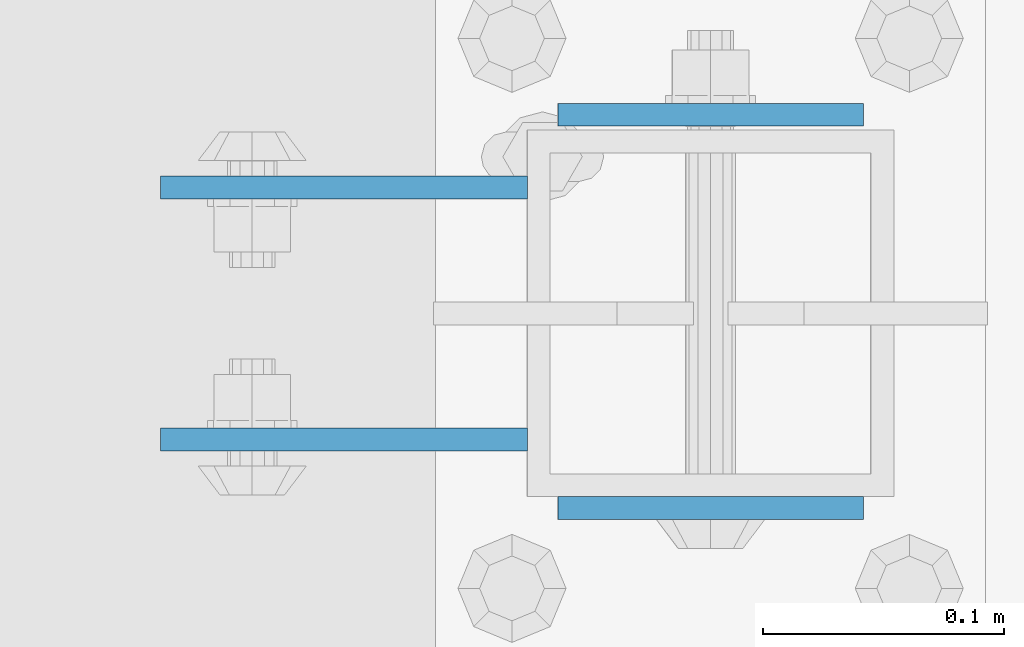
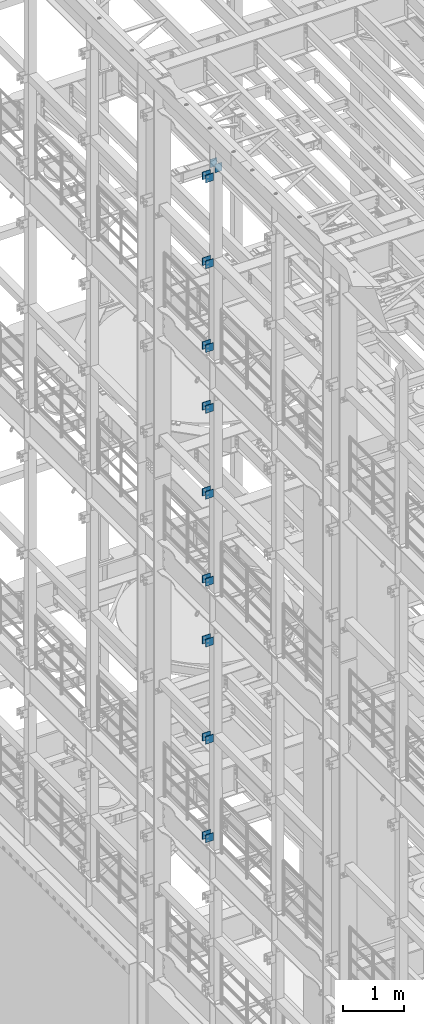
# One storey, part 1255 of 1876: 20 beams, 4 elements without a shape of their own.
"""IFC2X3 building model written with IfcOpenShell, lengths in millimetres."""

from ifc_helpers import new_model, si_unit, frame, origin_with_axes, place, context, subcontext, project, spatial, faceted_brep, material, type_object, element, aggregate, save


model = new_model("IFC2X3")

# Units and contexts
model_context = context("Model", 3, precision=1e-05, world=origin_with_axes())
body_context = subcontext(model_context, "Body", "Model", "MODEL_VIEW")
ifc_project = project(units=[si_unit("LENGTHUNIT", "METRE", prefix="MILLI"), si_unit("AREAUNIT", "SQUARE_METRE"), si_unit("VOLUMEUNIT", "CUBIC_METRE"), si_unit("MASSUNIT", "GRAM", prefix="KILO"), si_unit("TIMEUNIT", "SECOND"), si_unit("PLANEANGLEUNIT", "RADIAN"), si_unit("SOLIDANGLEUNIT", "STERADIAN"), si_unit("THERMODYNAMICTEMPERATUREUNIT", "DEGREE_CELSIUS"), si_unit("LUMINOUSINTENSITYUNIT", "LUMEN")], contexts=[model_context])

# Site, building, storey
site_placement = place(None, origin_with_axes())
site = spatial("IfcSite", under=ifc_project, at=site_placement, CompositionType="ELEMENT")
building_placement = place(site_placement, origin_with_axes())
building = spatial("IfcBuilding", under=site, at=building_placement, Name="Undefined", CompositionType="ELEMENT")
storey_placement = place(building_placement, origin_with_axes())
storey = spatial("IfcBuildingStorey", under=building, at=storey_placement, Name="Undefined", CompositionType="ELEMENT", Elevation=0.0)

# Assembly, beams
assembly_1_placement = place(storey_placement, origin_with_axes())
assembly_1 = element("IfcElementAssembly", 1, at=assembly_1_placement, inside=storey, Name="BEAM", AssemblyPlace="NOTDEFINED", PredefinedType="RIGID_FRAME")
ifc_material = material(Name="STEEL/A36")
beam_type_1 = type_object("IfcBeamType", PredefinedType="NOTDEFINED")
beam_1_placement = place(assembly_1_placement, frame((-76.2000002548894, 5640.3875, 18275.3), z_axis=(0.0, 0.0, -1.0), x_axis=(-1.0, 0.0, 0.0)))
beam_1 = element("IfcBeam", 2, at=beam_1_placement, type_object=beam_type_1, material=ifc_material, Name="PLATE", context=body_context, shape_type="Brep", body=[
    faceted_brep([(0.0, 4.76249999999982, -76.1999999999998), (3.63797880709171e-12, 4.76249999999982, 76.1999969482422), (152.399993896484, 4.76250000000073, 76.1999969482422), (152.4, 4.76249999999982, -76.1999999999998), (3.63797880709171e-12, -4.76249999999982, 76.1999969482422), (152.399993896484, -4.76250000000073, 76.1999969482422), (0.0, -4.76249999999982, -76.1999999999998), (152.4, -4.76249999999982, -76.1999999999998)], [[[0, 1, 2, 3]], [[4, 5, 2, 1]], [[4, 6, 7, 5]], [[6, 0, 3, 7]], [[5, 7, 3, 2]], [[6, 4, 1, 0]]]),
])
beam_2_placement = place(assembly_1_placement, frame((-76.2000002548894, 5535.6125, 18275.3), z_axis=(0.0, 0.0, -1.0), x_axis=(-1.0, 0.0, 0.0)))
beam_2 = element("IfcBeam", 3, at=beam_2_placement, type_object=beam_type_1, material=ifc_material, Name="PLATE", context=body_context, shape_type="Brep", body=[
    faceted_brep([(0.0, 4.76249999999982, -76.1999999999998), (3.63797880709171e-12, 4.76249999999982, 76.1999969482422), (152.399993896484, 4.76250000000073, 76.1999969482422), (152.4, 4.76249999999982, -76.1999999999998), (3.63797880709171e-12, -4.76249999999982, 76.1999969482422), (152.399993896484, -4.76250000000073, 76.1999969482422), (0.0, -4.76249999999982, -76.1999999999998), (152.4, -4.76249999999982, -76.1999999999998)], [[[0, 1, 2, 3]], [[4, 5, 2, 1]], [[4, 6, 7, 5]], [[6, 0, 3, 7]], [[5, 7, 3, 2]], [[6, 4, 1, 0]]]),
])
beam_3_placement = place(assembly_1_placement, frame((-76.2000002548895, 5640.3875, 21678.9), z_axis=(0.0, 0.0, -1.0), x_axis=(-1.0, 0.0, 0.0)))
beam_3 = element("IfcBeam", 4, at=beam_3_placement, type_object=beam_type_1, material=ifc_material, Name="PLATE", context=body_context, shape_type="Brep", body=[
    faceted_brep([(0.0, 4.76249999999982, -76.1999999999998), (3.63797880709171e-12, 4.76249999999982, 76.1999969482422), (152.399993896484, 4.76250000000073, 76.1999969482422), (152.4, 4.76249999999982, -76.1999999999998), (3.63797880709171e-12, -4.76249999999982, 76.1999969482422), (152.399993896484, -4.76250000000073, 76.1999969482422), (0.0, -4.76249999999982, -76.1999999999998), (152.4, -4.76249999999982, -76.1999999999998)], [[[0, 1, 2, 3]], [[4, 5, 2, 1]], [[4, 6, 7, 5]], [[6, 0, 3, 7]], [[5, 7, 3, 2]], [[6, 4, 1, 0]]]),
])
beam_4_placement = place(assembly_1_placement, frame((-76.2000002548895, 5535.6125, 21678.9), z_axis=(0.0, 0.0, -1.0), x_axis=(-1.0, 0.0, 0.0)))
beam_4 = element("IfcBeam", 5, at=beam_4_placement, type_object=beam_type_1, material=ifc_material, Name="PLATE", context=body_context, shape_type="Brep", body=[
    faceted_brep([(0.0, 4.76249999999982, -76.1999999999998), (3.63797880709171e-12, 4.76249999999982, 76.1999969482422), (152.399993896484, 4.76250000000073, 76.1999969482422), (152.4, 4.76249999999982, -76.1999999999998), (3.63797880709171e-12, -4.76249999999982, 76.1999969482422), (152.399993896484, -4.76250000000073, 76.1999969482422), (0.0, -4.76249999999982, -76.1999999999998), (152.4, -4.76249999999982, -76.1999999999998)], [[[0, 1, 2, 3]], [[4, 5, 2, 1]], [[4, 6, 7, 5]], [[6, 0, 3, 7]], [[5, 7, 3, 2]], [[6, 4, 1, 0]]]),
])
beam_5_placement = place(assembly_1_placement, frame((-76.2000002548895, 5640.3875, 19958.05), z_axis=(0.0, 0.0, -1.0), x_axis=(-1.0, 0.0, 0.0)))
beam_5 = element("IfcBeam", 6, at=beam_5_placement, type_object=beam_type_1, material=ifc_material, Name="PLATE", context=body_context, shape_type="Brep", body=[
    faceted_brep([(0.0, 4.76249999999982, -76.1999999999998), (3.63797880709171e-12, 4.76249999999982, 76.1999969482422), (152.399993896484, 4.76250000000073, 76.1999969482422), (152.4, 4.76249999999982, -76.1999999999998), (3.63797880709171e-12, -4.76249999999982, 76.1999969482422), (152.399993896484, -4.76250000000073, 76.1999969482422), (0.0, -4.76249999999982, -76.1999999999998), (152.4, -4.76249999999982, -76.1999999999998)], [[[0, 1, 2, 3]], [[4, 5, 2, 1]], [[4, 6, 7, 5]], [[6, 0, 3, 7]], [[5, 7, 3, 2]], [[6, 4, 1, 0]]]),
])
beam_6_placement = place(assembly_1_placement, frame((-76.2000002548895, 5535.6125, 19958.05), z_axis=(0.0, 0.0, -1.0), x_axis=(-1.0, 0.0, 0.0)))
beam_6 = element("IfcBeam", 7, at=beam_6_placement, type_object=beam_type_1, material=ifc_material, Name="PLATE", context=body_context, shape_type="Brep", body=[
    faceted_brep([(0.0, 4.76249999999982, -76.1999999999998), (3.63797880709171e-12, 4.76249999999982, 76.1999969482422), (152.399993896484, 4.76250000000073, 76.1999969482422), (152.4, 4.76249999999982, -76.1999999999998), (3.63797880709171e-12, -4.76249999999982, 76.1999969482422), (152.399993896484, -4.76250000000073, 76.1999969482422), (0.0, -4.76249999999982, -76.1999999999998), (152.4, -4.76249999999982, -76.1999999999998)], [[[0, 1, 2, 3]], [[4, 5, 2, 1]], [[4, 6, 7, 5]], [[6, 0, 3, 7]], [[5, 7, 3, 2]], [[6, 4, 1, 0]]]),
])
aggregate(assembly_1, [beam_1, beam_2, beam_3, beam_4, beam_5, beam_6])

assembly_2_placement = place(storey_placement, origin_with_axes())
assembly_2 = element("IfcElementAssembly", 8, at=assembly_2_placement, inside=storey, Name="BEAM", AssemblyPlace="NOTDEFINED", PredefinedType="RIGID_FRAME")
beam_7_placement = place(assembly_2_placement, frame((-76.1999999999999, 5640.3875, 13589.0), z_axis=(0.0, 0.0, -1.0), x_axis=(-1.0, 0.0, 0.0)))
beam_7 = element("IfcBeam", 9, at=beam_7_placement, type_object=beam_type_1, material=ifc_material, Name="PLATE", context=body_context, shape_type="Brep", body=[
    faceted_brep([(0.0, 4.76249999999982, -76.1999999999998), (3.63797880709171e-12, 4.76249999999982, 76.1999969482422), (152.399993896484, 4.76250000000073, 76.1999969482422), (152.4, 4.76249999999982, -76.1999999999998), (3.63797880709171e-12, -4.76249999999982, 76.1999969482422), (152.399993896484, -4.76250000000073, 76.1999969482422), (0.0, -4.76249999999982, -76.1999999999998), (152.4, -4.76249999999982, -76.1999999999998)], [[[0, 1, 2, 3]], [[4, 5, 2, 1]], [[4, 6, 7, 5]], [[6, 0, 3, 7]], [[5, 7, 3, 2]], [[6, 4, 1, 0]]]),
])
beam_8_placement = place(assembly_2_placement, frame((-76.1999999999999, 5535.6125, 13589.0), z_axis=(0.0, 0.0, -1.0), x_axis=(-1.0, 0.0, 0.0)))
beam_8 = element("IfcBeam", 10, at=beam_8_placement, type_object=beam_type_1, material=ifc_material, Name="PLATE", context=body_context, shape_type="Brep", body=[
    faceted_brep([(0.0, 4.76249999999982, -76.1999999999998), (3.63797880709171e-12, 4.76249999999982, 76.1999969482422), (152.399993896484, 4.76250000000073, 76.1999969482422), (152.4, 4.76249999999982, -76.1999999999998), (3.63797880709171e-12, -4.76249999999982, 76.1999969482422), (152.399993896484, -4.76250000000073, 76.1999969482422), (0.0, -4.76249999999982, -76.1999999999998), (152.4, -4.76249999999982, -76.1999999999998)], [[[0, 1, 2, 3]], [[4, 5, 2, 1]], [[4, 6, 7, 5]], [[6, 0, 3, 7]], [[5, 7, 3, 2]], [[6, 4, 1, 0]]]),
])
beam_9_placement = place(assembly_2_placement, frame((-76.2, 5640.3875, 17056.1), z_axis=(0.0, 0.0, -1.0), x_axis=(-1.0, 0.0, 0.0)))
beam_9 = element("IfcBeam", 11, at=beam_9_placement, type_object=beam_type_1, material=ifc_material, Name="PLATE", context=body_context, shape_type="Brep", body=[
    faceted_brep([(0.0, 4.76249999999982, -76.1999999999998), (3.63797880709171e-12, 4.76249999999982, 76.1999969482422), (152.399993896484, 4.76250000000073, 76.1999969482422), (152.4, 4.76249999999982, -76.1999999999998), (3.63797880709171e-12, -4.76249999999982, 76.1999969482422), (152.399993896484, -4.76250000000073, 76.1999969482422), (0.0, -4.76249999999982, -76.1999999999998), (152.4, -4.76249999999982, -76.1999999999998)], [[[0, 1, 2, 3]], [[4, 5, 2, 1]], [[4, 6, 7, 5]], [[6, 0, 3, 7]], [[5, 7, 3, 2]], [[6, 4, 1, 0]]]),
])
beam_10_placement = place(assembly_2_placement, frame((-76.2, 5535.6125, 17056.1), z_axis=(0.0, 0.0, -1.0), x_axis=(-1.0, 0.0, 0.0)))
beam_10 = element("IfcBeam", 12, at=beam_10_placement, type_object=beam_type_1, material=ifc_material, Name="PLATE", context=body_context, shape_type="Brep", body=[
    faceted_brep([(0.0, 4.76249999999982, -76.1999999999998), (3.63797880709171e-12, 4.76249999999982, 76.1999969482422), (152.399993896484, 4.76250000000073, 76.1999969482422), (152.4, 4.76249999999982, -76.1999999999998), (3.63797880709171e-12, -4.76249999999982, 76.1999969482422), (152.399993896484, -4.76250000000073, 76.1999969482422), (0.0, -4.76249999999982, -76.1999999999998), (152.4, -4.76249999999982, -76.1999999999998)], [[[0, 1, 2, 3]], [[4, 5, 2, 1]], [[4, 6, 7, 5]], [[6, 0, 3, 7]], [[5, 7, 3, 2]], [[6, 4, 1, 0]]]),
])
beam_11_placement = place(assembly_2_placement, frame((-76.2, 5640.3875, 15335.25), z_axis=(0.0, 0.0, -1.0), x_axis=(-1.0, 0.0, 0.0)))
beam_11 = element("IfcBeam", 13, at=beam_11_placement, type_object=beam_type_1, material=ifc_material, Name="PLATE", context=body_context, shape_type="Brep", body=[
    faceted_brep([(0.0, 4.76249999999982, -76.1999999999998), (3.63797880709171e-12, 4.76249999999982, 76.1999969482422), (152.399993896484, 4.76250000000073, 76.1999969482422), (152.4, 4.76249999999982, -76.1999999999998), (3.63797880709171e-12, -4.76249999999982, 76.1999969482422), (152.399993896484, -4.76250000000073, 76.1999969482422), (0.0, -4.76249999999982, -76.1999999999998), (152.4, -4.76249999999982, -76.1999999999998)], [[[0, 1, 2, 3]], [[4, 5, 2, 1]], [[4, 6, 7, 5]], [[6, 0, 3, 7]], [[5, 7, 3, 2]], [[6, 4, 1, 0]]]),
])
beam_12_placement = place(assembly_2_placement, frame((-76.2, 5535.6125, 15335.25), z_axis=(0.0, 0.0, -1.0), x_axis=(-1.0, 0.0, 0.0)))
beam_12 = element("IfcBeam", 14, at=beam_12_placement, type_object=beam_type_1, material=ifc_material, Name="PLATE", context=body_context, shape_type="Brep", body=[
    faceted_brep([(0.0, 4.76249999999982, -76.1999999999998), (3.63797880709171e-12, 4.76249999999982, 76.1999969482422), (152.399993896484, 4.76250000000073, 76.1999969482422), (152.4, 4.76249999999982, -76.1999999999998), (3.63797880709171e-12, -4.76249999999982, 76.1999969482422), (152.399993896484, -4.76250000000073, 76.1999969482422), (0.0, -4.76249999999982, -76.1999999999998), (152.4, -4.76249999999982, -76.1999999999998)], [[[0, 1, 2, 3]], [[4, 5, 2, 1]], [[4, 6, 7, 5]], [[6, 0, 3, 7]], [[5, 7, 3, 2]], [[6, 4, 1, 0]]]),
])
aggregate(assembly_2, [beam_7, beam_8, beam_9, beam_10, beam_11, beam_12])

assembly_3_placement = place(storey_placement, origin_with_axes())
assembly_3 = element("IfcElementAssembly", 15, at=assembly_3_placement, inside=storey, Name="BEAM", AssemblyPlace="NOTDEFINED", PredefinedType="RIGID_FRAME")
beam_13_placement = place(assembly_3_placement, frame((-76.1999999999999, 5640.3875, 12369.8), z_axis=(0.0, 0.0, -1.0), x_axis=(-1.0, 0.0, 0.0)))
beam_13 = element("IfcBeam", 16, at=beam_13_placement, type_object=beam_type_1, material=ifc_material, Name="PLATE", context=body_context, shape_type="Brep", body=[
    faceted_brep([(0.0, 4.76249999999982, -76.1999999999998), (3.63797880709171e-12, 4.76249999999982, 76.1999969482422), (152.399993896484, 4.76250000000073, 76.1999969482422), (152.4, 4.76249999999982, -76.1999999999998), (3.63797880709171e-12, -4.76249999999982, 76.1999969482422), (152.399993896484, -4.76250000000073, 76.1999969482422), (0.0, -4.76249999999982, -76.1999999999998), (152.4, -4.76249999999982, -76.1999999999998)], [[[0, 1, 2, 3]], [[4, 5, 2, 1]], [[4, 6, 7, 5]], [[6, 0, 3, 7]], [[5, 7, 3, 2]], [[6, 4, 1, 0]]]),
])
beam_14_placement = place(assembly_3_placement, frame((-76.1999999999999, 5535.6125, 12369.8), z_axis=(0.0, 0.0, -1.0), x_axis=(-1.0, 0.0, 0.0)))
beam_14 = element("IfcBeam", 17, at=beam_14_placement, type_object=beam_type_1, material=ifc_material, Name="PLATE", context=body_context, shape_type="Brep", body=[
    faceted_brep([(0.0, 4.76249999999982, -76.1999999999998), (3.63797880709171e-12, 4.76249999999982, 76.1999969482422), (152.399993896484, 4.76250000000073, 76.1999969482422), (152.4, 4.76249999999982, -76.1999999999998), (3.63797880709171e-12, -4.76249999999982, 76.1999969482422), (152.399993896484, -4.76250000000073, 76.1999969482422), (0.0, -4.76249999999982, -76.1999999999998), (152.4, -4.76249999999982, -76.1999999999998)], [[[0, 1, 2, 3]], [[4, 5, 2, 1]], [[4, 6, 7, 5]], [[6, 0, 3, 7]], [[5, 7, 3, 2]], [[6, 4, 1, 0]]]),
])
beam_15_placement = place(assembly_3_placement, frame((-76.2, 5640.3875, 8445.5), z_axis=(0.0, 0.0, -1.0), x_axis=(-1.0, 0.0, 0.0)))
beam_15 = element("IfcBeam", 18, at=beam_15_placement, type_object=beam_type_1, material=ifc_material, Name="PLATE", context=body_context, shape_type="Brep", body=[
    faceted_brep([(0.0, 4.76249999999982, -76.1999999999998), (3.63797880709171e-12, 4.76249999999982, 76.1999969482422), (152.399993896484, 4.76250000000073, 76.1999969482422), (152.4, 4.76249999999982, -76.1999999999998), (3.63797880709171e-12, -4.76249999999982, 76.1999969482422), (152.399993896484, -4.76250000000073, 76.1999969482422), (0.0, -4.76249999999982, -76.1999999999998), (152.4, -4.76249999999982, -76.1999999999998)], [[[0, 1, 2, 3]], [[4, 5, 2, 1]], [[4, 6, 7, 5]], [[6, 0, 3, 7]], [[5, 7, 3, 2]], [[6, 4, 1, 0]]]),
])
beam_16_placement = place(assembly_3_placement, frame((-76.2, 5535.6125, 8445.5), z_axis=(0.0, 0.0, -1.0), x_axis=(-1.0, 0.0, 0.0)))
beam_16 = element("IfcBeam", 19, at=beam_16_placement, type_object=beam_type_1, material=ifc_material, Name="PLATE", context=body_context, shape_type="Brep", body=[
    faceted_brep([(0.0, 4.76249999999982, -76.1999999999998), (3.63797880709171e-12, 4.76249999999982, 76.1999969482422), (152.399993896484, 4.76250000000073, 76.1999969482422), (152.4, 4.76249999999982, -76.1999999999998), (3.63797880709171e-12, -4.76249999999982, 76.1999969482422), (152.399993896484, -4.76250000000073, 76.1999969482422), (0.0, -4.76249999999982, -76.1999999999998), (152.4, -4.76249999999982, -76.1999999999998)], [[[0, 1, 2, 3]], [[4, 5, 2, 1]], [[4, 6, 7, 5]], [[6, 0, 3, 7]], [[5, 7, 3, 2]], [[6, 4, 1, 0]]]),
])
beam_17_placement = place(assembly_3_placement, frame((-76.2, 5640.3875, 10420.35), z_axis=(0.0, 0.0, -1.0), x_axis=(-1.0, 0.0, 0.0)))
beam_17 = element("IfcBeam", 20, at=beam_17_placement, type_object=beam_type_1, material=ifc_material, Name="PLATE", context=body_context, shape_type="Brep", body=[
    faceted_brep([(0.0, 4.76249999999982, -76.1999999999998), (3.63797880709171e-12, 4.76249999999982, 76.1999969482422), (152.399993896484, 4.76250000000073, 76.1999969482422), (152.4, 4.76249999999982, -76.1999999999998), (3.63797880709171e-12, -4.76249999999982, 76.1999969482422), (152.399993896484, -4.76250000000073, 76.1999969482422), (0.0, -4.76249999999982, -76.1999999999998), (152.4, -4.76249999999982, -76.1999999999998)], [[[0, 1, 2, 3]], [[4, 5, 2, 1]], [[4, 6, 7, 5]], [[6, 0, 3, 7]], [[5, 7, 3, 2]], [[6, 4, 1, 0]]]),
])
beam_18_placement = place(assembly_3_placement, frame((-76.2, 5535.6125, 10420.35), z_axis=(0.0, 0.0, -1.0), x_axis=(-1.0, 0.0, 0.0)))
beam_18 = element("IfcBeam", 21, at=beam_18_placement, type_object=beam_type_1, material=ifc_material, Name="PLATE", context=body_context, shape_type="Brep", body=[
    faceted_brep([(0.0, 4.76249999999982, -76.1999999999998), (3.63797880709171e-12, 4.76249999999982, 76.1999969482422), (152.399993896484, 4.76250000000073, 76.1999969482422), (152.4, 4.76249999999982, -76.1999999999998), (3.63797880709171e-12, -4.76249999999982, 76.1999969482422), (152.399993896484, -4.76250000000073, 76.1999969482422), (0.0, -4.76249999999982, -76.1999999999998), (152.4, -4.76249999999982, -76.1999999999998)], [[[0, 1, 2, 3]], [[4, 5, 2, 1]], [[4, 6, 7, 5]], [[6, 0, 3, 7]], [[5, 7, 3, 2]], [[6, 4, 1, 0]]]),
])
aggregate(assembly_3, [beam_13, beam_14, beam_15, beam_16, beam_17, beam_18])

assembly_4_placement = place(storey_placement, origin_with_axes())
assembly_4 = element("IfcElementAssembly", 22, at=assembly_4_placement, inside=storey, Name="BEAM", AssemblyPlace="NOTDEFINED", PredefinedType="RIGID_FRAME")
beam_type_2 = type_object("IfcBeamType", PredefinedType="NOTDEFINED")
beam_19_placement = place(assembly_4_placement, frame((-63.5, 5670.55, 21850.35), z_axis=(0.0, 0.0, -1.0), x_axis=(1.0, 0.0, 0.0)))
beam_19 = element("IfcBeam", 23, at=beam_19_placement, type_object=beam_type_2, material=ifc_material, Name="PLATE", context=body_context, shape_type="Brep", body=[
    faceted_brep([(0.0, 4.76249999999982, -82.5499999999993), (0.0, 4.76249999999982, 82.5499999999993), (127.0, 4.76249999999982, 82.5499999999993), (127.0, 4.76249999999982, -82.5499999999993), (0.0, -4.76249999999982, 82.5499999999993), (127.0, -4.76249999999982, 82.5499999999993), (0.0, -4.76249999999982, -82.5499999999993), (127.0, -4.76249999999982, -82.5499999999993)], [[[0, 1, 2, 3]], [[1, 4, 5, 2]], [[4, 6, 7, 5]], [[6, 0, 3, 7]], [[5, 7, 3, 2]], [[6, 4, 1, 0]]]),
])
beam_20_placement = place(assembly_4_placement, frame((-63.5, 5507.0375, 21850.35), z_axis=(0.0, 0.0, -1.0), x_axis=(1.0, 0.0, 0.0)))
beam_20 = element("IfcBeam", 24, at=beam_20_placement, type_object=beam_type_2, material=ifc_material, Name="PLATE", context=body_context, shape_type="Brep", body=[
    faceted_brep([(0.0, 4.76249999999982, -82.5499999999993), (0.0, 4.76249999999982, 82.5499999999993), (127.0, 4.76249999999982, 82.5499999999993), (127.0, 4.76249999999982, -82.5499999999993), (0.0, -4.76249999999982, 82.5499999999993), (127.0, -4.76249999999982, 82.5499999999993), (0.0, -4.76249999999982, -82.5499999999993), (127.0, -4.76249999999982, -82.5499999999993)], [[[0, 1, 2, 3]], [[1, 4, 5, 2]], [[4, 6, 7, 5]], [[6, 0, 3, 7]], [[5, 7, 3, 2]], [[6, 4, 1, 0]]]),
])
aggregate(assembly_4, [beam_19, beam_20])

save(model, "model.ifc")
